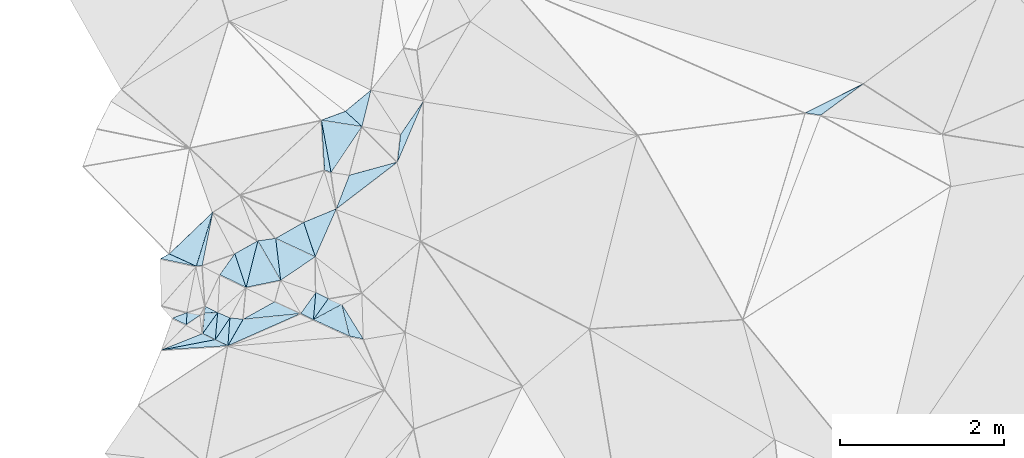
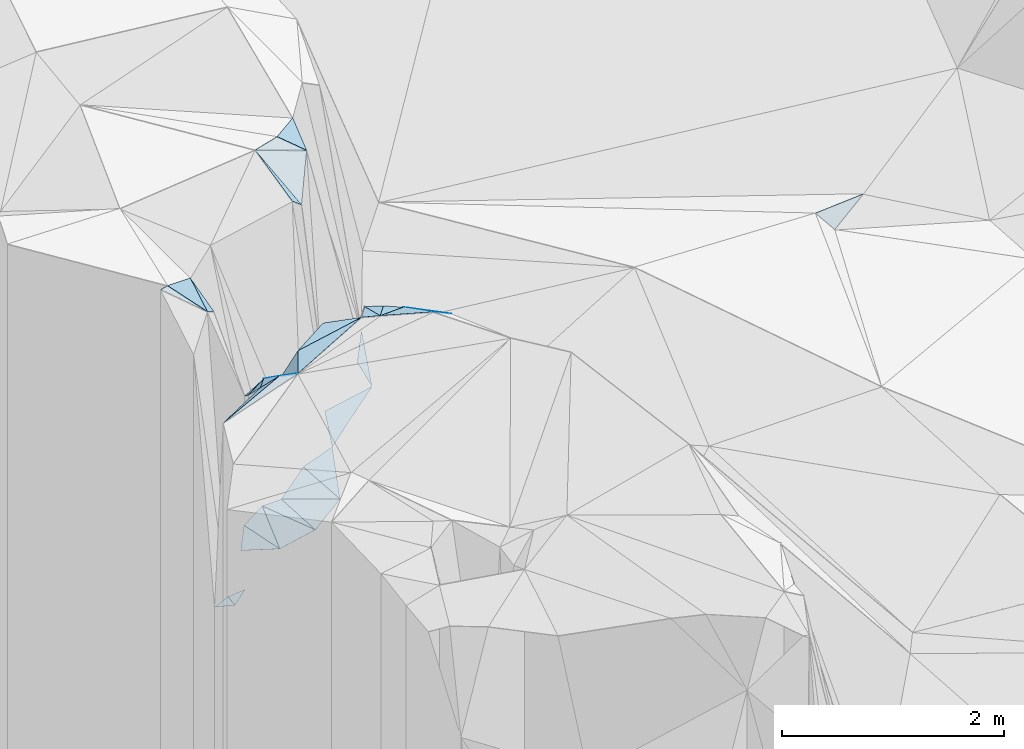
# One storey, part 174 of 275: 34 plates.
"""IFC2X3 building model written with IfcOpenShell, lengths in millimetres."""

import ifcopenshell
import ifcopenshell.guid

model = None  # the IFC model being written
_history = None  # IfcOwnerHistory: only IFC2X3 demands one
_inside = {}  # id of a spatial element -> (the spatial element, [elements in it])
_under = {}  # id of a project, library or spatial element -> (it, [spatial elements below it])
_declared = {}  # id of a project -> (the project, [libraries it declares])
_typed = {}  # id of a type object -> (the type object, [elements of that type])
_made_of = {}  # id of a material, layer set ... -> (it, [elements and type objects made of it])


def new_model(schema):
    """Start an empty IFC model of exactly this schema.

    Asked for "IFC4X3", IfcOpenShell would pick the latest addendum, in which some entities
    have other attributes; the version numbers below select the first issue.
    IFC2X3 requires an IfcOwnerHistory on every rooted entity: one is made here for all.
    """
    global model, _history
    if schema == "IFC4X3":
        model = ifcopenshell.file(schema_version=(4, 3, 0, 0))
    else:
        model = ifcopenshell.file(schema=schema)
    _inside.clear()
    _under.clear()
    _declared.clear()
    _typed.clear()
    _made_of.clear()
    _history = None
    if model.schema == "IFC2X3":
        org = make("IfcOrganization", Name="unknown")
        user = make(
            "IfcPersonAndOrganization",
            ThePerson=make("IfcPerson", FamilyName="unknown"),
            TheOrganization=org,
        )
        app = make(
            "IfcApplication",
            ApplicationDeveloper=org,
            Version="unknown",
            ApplicationFullName="unknown",
            ApplicationIdentifier="unknown",
        )
        _history = make(
            "IfcOwnerHistory",
            OwningUser=user,
            OwningApplication=app,
            ChangeAction="ADDED",
            CreationDate=0,
        )
    return model


def make(cls, **values):
    """One entity of the class cls with the attributes given. An attribute that is None is left unset."""
    return model.create_entity(
        cls, **{name: value for name, value in values.items() if value is not None}
    )


def rooted(cls, **values):
    """An entity with a GlobalId (a new one), such as an element, a storey or a relation."""
    return make(cls, GlobalId=ifcopenshell.guid.new(), OwnerHistory=_history, **values)


def si_unit(unit_type, name, prefix=None):
    """IfcSIUnit, for example si_unit("LENGTHUNIT", "METRE", prefix="MILLI")."""
    return make("IfcSIUnit", UnitType=unit_type, Prefix=prefix, Name=name)


def assignment(units):
    """IfcUnitAssignment: the units of a project."""
    return None if units is None else make("IfcUnitAssignment", Units=units)


def point(xyz):
    """IfcCartesianPoint."""
    return None if xyz is None else make("IfcCartesianPoint", Coordinates=xyz)


def direction(xyz):
    """IfcDirection."""
    return None if xyz is None else make("IfcDirection", DirectionRatios=xyz)


def frame(location, z_axis=None, x_axis=None):
    """IfcAxis2Placement3D, a coordinate frame: its origin and axes. An axis left out is left unset."""
    return make(
        "IfcAxis2Placement3D",
        Location=point(location),
        Axis=direction(z_axis),
        RefDirection=direction(x_axis),
    )


def origin_with_axes():
    """The frame at (0, 0, 0) with the z axis (0, 0, 1) and the x axis (1, 0, 0) written out."""
    return frame((0.0, 0.0, 0.0), z_axis=(0.0, 0.0, 1.0), x_axis=(1.0, 0.0, 0.0))


def place(relative_to, where):
    """IfcLocalPlacement: puts the frame where relative to a parent placement (None: the world)."""
    return make(
        "IfcLocalPlacement", PlacementRelTo=relative_to, RelativePlacement=where
    )


def context(
    kind, dimensions, precision=None, world=None, true_north=None, identifier=None
):
    """IfcGeometricRepresentationContext, for example the 3D "Model" context."""
    return make(
        "IfcGeometricRepresentationContext",
        ContextIdentifier=identifier,
        ContextType=kind,
        CoordinateSpaceDimension=dimensions,
        Precision=precision,
        WorldCoordinateSystem=world,
        TrueNorth=true_north,
    )


def subcontext(parent, identifier, kind, view, scale=None):
    """IfcGeometricRepresentationSubContext, for example "Body" below "Model"."""
    return make(
        "IfcGeometricRepresentationSubContext",
        ContextIdentifier=identifier,
        ContextType=kind,
        ParentContext=parent,
        TargetScale=scale,
        TargetView=view,
    )


def project(units=None, contexts=None):
    """IfcProject with its units and contexts."""
    return rooted(
        "IfcProject",
        Name="project",
        RepresentationContexts=contexts,
        UnitsInContext=assignment(units),
    )


def spatial(cls, under=None, at=None, **own):
    """A site, building, storey or space (cls), placed at a placement, below another one or the project."""
    s = rooted(cls, ObjectPlacement=at, **own)
    if under is not None:
        _under.setdefault(under.id(), (under, []))[1].append(s)
    return s


def polyline(points):
    """IfcPolyline through the points."""
    return make("IfcPolyline", Points=[point(p) for p in points])


def outline(outer, holes=None, kind="AREA"):
    """IfcArbitraryClosedProfileDef: a profile drawn as a closed curve; with holes, ...WithVoids."""
    if holes is None:
        return make("IfcArbitraryClosedProfileDef", ProfileType=kind, OuterCurve=outer)
    return make(
        "IfcArbitraryProfileDefWithVoids",
        ProfileType=kind,
        OuterCurve=outer,
        InnerCurves=holes,
    )


def extrude(swept, where, along, depth):
    """IfcExtrudedAreaSolid: the profile swept, set in the frame where, extruded along a direction by depth."""
    return make(
        "IfcExtrudedAreaSolid",
        SweptArea=swept,
        Position=where,
        ExtrudedDirection=direction(along),
        Depth=depth,
    )


def shape(context_of_items, identifier, shape_type, items):
    """IfcShapeRepresentation: the items that make up one representation, for example the "Body"."""
    return make(
        "IfcShapeRepresentation",
        ContextOfItems=context_of_items,
        RepresentationIdentifier=identifier,
        RepresentationType=shape_type,
        Items=items,
    )


def material(Name=None, Category=None):
    """IfcMaterial."""
    return make("IfcMaterial", Name=Name, Category=Category)


def made_of(thing, what):
    """Note that an element or type object is made of a material, layer set ...; save() writes the relation."""
    if what is not None:
        _made_of.setdefault(what.id(), (what, []))[1].append(thing)
    return thing


def type_object(cls, material=None, **own):
    """A type object (cls), such as IfcWallType, which elements share."""
    return made_of(rooted(cls, **own), material)


def element(
    cls,
    number,
    at=None,
    inside=None,
    cuts=None,
    type_object=None,
    material=None,
    context=None,
    identifier="Body",
    shape_type=None,
    held_by="IfcProductDefinitionShape",
    body=None,
    shapes=None,
    **own,
):
    """One element of the class cls, such as IfcWall. Its Tag is "e" and its number.

    at: its placement. inside: the storey or other place that contains it. cuts: it is an
    opening in that element (IfcRelVoidsElement). A single representation is given by context,
    identifier, shape_type and body (its items); several are given by shapes. held_by: the class
    of the entity that holds the representations. save() writes the other relations.
    """
    e = rooted(cls, Tag="e%d" % number, ObjectPlacement=at, **own)
    if body is not None:
        shapes = [shape(context, identifier, shape_type, body)]
    if shapes is not None:
        e.Representation = make(held_by, Representations=shapes)
    if inside is not None:
        _inside.setdefault(inside.id(), (inside, []))[1].append(e)
    if cuts is not None:
        rooted(
            "IfcRelVoidsElement", RelatingBuildingElement=cuts, RelatedOpeningElement=e
        )
    if type_object is not None:
        _typed.setdefault(type_object.id(), (type_object, []))[1].append(e)
    return made_of(e, material)


def aggregate(whole, parts):
    """IfcRelAggregates: a whole, such as a stair, and the parts it consists of."""
    return rooted("IfcRelAggregates", RelatingObject=whole, RelatedObjects=parts)


def save(model, path):
    """Write the relations noted so far, then the file.

    IfcRelAggregates (storeys below a building ...), IfcRelContainedInSpatialStructure (elements
    in a storey), IfcRelDefinesByType, IfcRelAssociatesMaterial and IfcRelDeclares: one each for
    every whole, place, type object, material and project.
    """
    for whole, parts in _under.values():
        aggregate(whole, parts)
    for where, things in _inside.values():
        rooted(
            "IfcRelContainedInSpatialStructure",
            RelatedElements=things,
            RelatingStructure=where,
        )
    for kind, things in _typed.values():
        rooted("IfcRelDefinesByType", RelatedObjects=things, RelatingType=kind)
    for what, things in _made_of.values():
        rooted("IfcRelAssociatesMaterial", RelatedObjects=things, RelatingMaterial=what)
    for by, libraries in _declared.values():
        rooted("IfcRelDeclares", RelatingContext=by, RelatedDefinitions=libraries)
    model.write(path)


model = new_model("IFC2X3")

# Units and contexts
model_context = context("Model", 3, precision=1e-05, world=origin_with_axes())
body_context = subcontext(model_context, "Body", "Model", "MODEL_VIEW")
ifc_project = project(units=[si_unit("LENGTHUNIT", "METRE", prefix="MILLI"), si_unit("AREAUNIT", "SQUARE_METRE"), si_unit("VOLUMEUNIT", "CUBIC_METRE"), si_unit("MASSUNIT", "GRAM", prefix="KILO"), si_unit("TIMEUNIT", "SECOND"), si_unit("PLANEANGLEUNIT", "RADIAN"), si_unit("SOLIDANGLEUNIT", "STERADIAN"), si_unit("THERMODYNAMICTEMPERATUREUNIT", "DEGREE_CELSIUS"), si_unit("LUMINOUSINTENSITYUNIT", "LUMEN")], contexts=[model_context])

# Site, building, storey
site_placement = place(None, origin_with_axes())
site = spatial("IfcSite", under=ifc_project, at=site_placement, CompositionType="ELEMENT")
building_placement = place(site_placement, origin_with_axes())
building = spatial("IfcBuilding", under=site, at=building_placement, Name="Undefined", CompositionType="ELEMENT")
storey_placement = place(building_placement, origin_with_axes())
storey = spatial("IfcBuildingStorey", under=building, at=storey_placement, Name="Undefined", CompositionType="ELEMENT", Elevation=0.0)

# Plates
ifc_material = material()
plate_type_1 = type_object("IfcPlateType", PredefinedType="NOTDEFINED")
plate_1_placement = place(storey_placement, frame((-136102.059956231, 93262.0576087373, 54479.5205283592), z_axis=(-0.119658069519682, 0.257357162709974, -0.958879156724504), x_axis=(0.353440063253771, 0.913586766906166, 0.201095353056975)))
element("IfcPlate", 1, at=plate_1_placement, inside=storey, type_object=plate_type_1, material=ifc_material, Name="00", context=body_context, shape_type="SweptSolid", body=[
    extrude(outline(polyline([(0.0, 0.0), (447.548889160156, 1.76078174263239e-09), (794.773498535156, 498.432586669922), (0.0, 0.0)])), frame((-8.85201319254618e-08, 2.18876761149539e-07, -0.5000001331573), z_axis=(0.0, 0.0, 1.0), x_axis=(1.0, 0.0, 0.0)), (0.0, 0.0, 1.0), 1.0),
])
plate_type_2 = type_object("IfcPlateType", PredefinedType="NOTDEFINED")
plate_2_placement = place(storey_placement, frame((-135041.539628917, 94572.7760186233, 54599.5185793243), z_axis=(-0.211432938409784, 0.168339358278525, -0.962786566695744), x_axis=(-0.392209356771163, -0.916879990058271, -0.0741815630186923)))
element("IfcPlate", 2, at=plate_2_placement, inside=storey, type_object=plate_type_2, material=ifc_material, Name="00", context=body_context, shape_type="SweptSolid", body=[
    extrude(outline(polyline([(0.0, 0.0), (808.826293945313, -1.57160684466362e-09), (483.911071777344, 99.6498031616211), (0.0, 0.0)])), frame((-8.85201319254618e-08, 2.18876761149539e-07, -0.5000001331573), z_axis=(0.0, 0.0, 1.0), x_axis=(1.0, 0.0, 0.0)), (0.0, 0.0, 1.0), 1.0),
])
plate_type_3 = type_object("IfcPlateType", PredefinedType="NOTDEFINED")
plate_3_placement = place(storey_placement, frame((-135774.293739208, 91679.1654943419, 56789.5865918103), z_axis=(-0.38020282266032, -0.414618868867303, -0.826762969187858), x_axis=(-0.924650624260084, 0.191278561828932, 0.329292779817736)))
element("IfcPlate", 3, at=plate_3_placement, inside=storey, type_object=plate_type_3, material=ifc_material, Name="00", context=body_context, shape_type="SweptSolid", body=[
    extrude(outline(polyline([(0.0, 0.0), (182.208679199219, -1.61526259034872e-09), (293.070587158203, 408.912750244141), (0.0, 0.0)])), frame((-8.85201319254618e-08, 2.18876761149539e-07, -0.5000001331573), z_axis=(0.0, 0.0, 1.0), x_axis=(1.0, 0.0, 0.0)), (0.0, 0.0, 1.0), 1.0),
])
plate_type_4 = type_object("IfcPlateType", PredefinedType="NOTDEFINED")
plate_4_placement = place(storey_placement, frame((-136283.879230588, 94340.7200018934, 57159.5710770173), z_axis=(-0.437740594458463, 0.269404179619282, -0.8577905105367), x_axis=(0.168438407355869, -0.912589430333872, -0.372570845035299)))
element("IfcPlate", 4, at=plate_4_placement, inside=storey, type_object=plate_type_4, material=ifc_material, Name="00", context=body_context, shape_type="SweptSolid", body=[
    extrude(outline(polyline([(0.0, 0.0), (697.853881835938, -1.03318598121405e-09), (637.955932617188, 78.1808013916016), (0.0, 0.0)])), frame((-8.85201319254618e-08, 2.18876761149539e-07, -0.5000001331573), z_axis=(0.0, 0.0, 1.0), x_axis=(1.0, 0.0, 0.0)), (0.0, 0.0, 1.0), 1.0),
])
plate_type_5 = type_object("IfcPlateType", PredefinedType="NOTDEFINED")
plate_5_placement = place(storey_placement, frame((-137056.178743322, 92872.9639135759, 54399.5049942715), z_axis=(-0.00587096308559347, 0.141336773812138, -0.989944164163224), x_axis=(0.497182111396843, -0.858518678310778, -0.125521420875052)))
element("IfcPlate", 5, at=plate_5_placement, inside=storey, type_object=plate_type_5, material=ifc_material, Name="00", context=body_context, shape_type="SweptSolid", body=[
    extrude(outline(polyline([(0.0, 0.0), (557.673767089844, 2.77941580861807e-09), (424.979675292969, 408.646881103516), (0.0, 0.0)])), frame((-8.85201319254618e-08, 2.18876761149539e-07, -0.5000001331573), z_axis=(0.0, 0.0, 1.0), x_axis=(1.0, 0.0, 0.0)), (0.0, 0.0, 1.0), 1.0),
])
plate_type_6 = type_object("IfcPlateType", PredefinedType="NOTDEFINED")
plate_6_placement = place(storey_placement, frame((-136778.962109518, 92394.1624225428, 54329.5044671322), z_axis=(-0.103421409674423, 0.0849979738680157, -0.990999170766196), x_axis=(-0.497182111452953, 0.858518678422199, 0.125521419890725)))
element("IfcPlate", 6, at=plate_6_placement, inside=storey, type_object=plate_type_6, material=ifc_material, Name="00", context=body_context, shape_type="SweptSolid", body=[
    extrude(outline(polyline([(0.0, 0.0), (557.673767089844, 2.77941580861807e-09), (473.395080566406, 202.477416992188), (0.0, 0.0)])), frame((-8.85201319254618e-08, 2.18876761149539e-07, -0.5000001331573), z_axis=(0.0, 0.0, 1.0), x_axis=(1.0, 0.0, 0.0)), (0.0, 0.0, 1.0), 1.0),
])
plate_type_7 = type_object("IfcPlateType", PredefinedType="NOTDEFINED")
plate_7_placement = place(storey_placement, frame((-137727.265224009, 91744.8296891179, 56619.6934589091), z_axis=(0.47813599606679, -0.62895166140146, -0.613029996725741), x_axis=(0.0599367299592715, 0.719723747835644, -0.691668500947675)))
element("IfcPlate", 7, at=plate_7_placement, inside=storey, type_object=plate_type_7, material=ifc_material, Name="00", context=body_context, shape_type="SweptSolid", body=[
    extrude(outline(polyline([(0.0, 0.0), (346.987030029297, 2.91038304567337e-11), (277.820190429688, 188.986633300781), (0.0, 0.0)])), frame((-8.85201319254618e-08, 2.18876761149539e-07, -0.5000001331573), z_axis=(0.0, 0.0, 1.0), x_axis=(1.0, 0.0, 0.0)), (0.0, 0.0, 1.0), 1.0),
])
plate_type_8 = type_object("IfcPlateType", PredefinedType="NOTDEFINED")
plate_8_placement = place(storey_placement, frame((-137235.677048889, 91918.8071439654, 56749.5034619952), z_axis=(0.115468442823451, -0.0227419632821938, -0.993050775045264), x_axis=(0.870682419546426, 0.483510126957181, 0.090166964142262)))
element("IfcPlate", 8, at=plate_8_placement, inside=storey, type_object=plate_type_8, material=ifc_material, Name="00", context=body_context, shape_type="SweptSolid", body=[
    extrude(outline(polyline([(0.0, 0.0), (443.621459960938, 5.15137799084187e-09), (651.907165527344, 280.565643310547), (0.0, 0.0)])), frame((-8.85201319254618e-08, 2.18876761149539e-07, -0.5000001331573), z_axis=(0.0, 0.0, 1.0), x_axis=(1.0, 0.0, 0.0)), (0.0, 0.0, 1.0), 1.0),
])
plate_type_9 = type_object("IfcPlateType", PredefinedType="NOTDEFINED")
plate_9_placement = place(storey_placement, frame((-137916.756443981, 92000.3592077676, 54229.5139100452), z_axis=(0.233638972256736, -0.0181857488493889, -0.972153336249793), x_axis=(0.960644936811236, -0.15017921580434, 0.233682495106778)))
element("IfcPlate", 9, at=plate_9_placement, inside=storey, type_object=plate_type_9, material=ifc_material, Name="00", context=body_context, shape_type="SweptSolid", body=[
    extrude(outline(polyline([(0.0, 0.0), (171.172424316406, -2.18278728425503e-09), (11.0999183654785, 147.230407714844), (0.0, 0.0)])), frame((-8.85201319254618e-08, 2.18876761149539e-07, -0.5000001331573), z_axis=(0.0, 0.0, 1.0), x_axis=(1.0, 0.0, 0.0)), (0.0, 0.0, 1.0), 1.0),
])
plate_type_10 = type_object("IfcPlateType", PredefinedType="NOTDEFINED")
plate_10_placement = place(storey_placement, frame((-136036.333452161, 92099.0304628926, 56699.5467298105), z_axis=(-0.15791157055637, -0.391595763291411, -0.906485903948119), x_axis=(0.221093133110351, -0.908718678826235, 0.354045462114331)))
element("IfcPlate", 10, at=plate_10_placement, inside=storey, type_object=plate_type_10, material=ifc_material, Name="00", context=body_context, shape_type="SweptSolid", body=[
    extrude(outline(polyline([(0.0, 0.0), (423.674407958984, -3.39059624820948e-09), (141.618179321289, 390.569183349609), (0.0, 0.0)])), frame((-8.85201319254618e-08, 2.18876761149539e-07, -0.5000001331573), z_axis=(0.0, 0.0, 1.0), x_axis=(1.0, 0.0, 0.0)), (0.0, 0.0, 1.0), 1.0),
])
plate_type_11 = type_object("IfcPlateType", PredefinedType="NOTDEFINED")
plate_11_placement = place(storey_placement, frame((-136533.931140818, 91988.4646315607, 56829.5063266509), z_axis=(0.122594291322905, -0.10109611628365, -0.987294391256933), x_axis=(-0.912234884951929, -0.403294824262796, -0.0719777701765088)))
element("IfcPlate", 11, at=plate_11_placement, inside=storey, type_object=plate_type_11, material=ifc_material, Name="00", context=body_context, shape_type="SweptSolid", body=[
    extrude(outline(polyline([(0.0, 0.0), (972.522521972656, -7.45058059692383e-09), (674.020385742188, 222.253234863281), (0.0, 0.0)])), frame((-8.85201319254618e-08, 2.18876761149539e-07, -0.5000001331573), z_axis=(0.0, 0.0, 1.0), x_axis=(1.0, 0.0, 0.0)), (0.0, 0.0, 1.0), 1.0),
])
plate_type_12 = type_object("IfcPlateType", PredefinedType="NOTDEFINED")
plate_12_placement = place(storey_placement, frame((-136380.864860161, 91913.9399705625, 56839.5263415291), z_axis=(-0.0878450910355811, -0.308088475756241, -0.947293371182944), x_axis=(-0.897906971206371, 0.436264420904473, -0.0586210381338215)))
element("IfcPlate", 12, at=plate_12_placement, inside=storey, type_object=plate_type_12, material=ifc_material, Name="00", context=body_context, shape_type="SweptSolid", body=[
    extrude(outline(polyline([(0.0, 0.0), (170.587219238281, -8.65838956087828e-10), (124.27660369873, 326.121643066406), (0.0, 0.0)])), frame((-8.85201319254618e-08, 2.18876761149539e-07, -0.5000001331573), z_axis=(0.0, 0.0, 1.0), x_axis=(1.0, 0.0, 0.0)), (0.0, 0.0, 1.0), 1.0),
])
plate_13_placement = place(storey_placement, frame((-137421.244802107, 91596.0211696216, 56759.5947142821), z_axis=(-0.166923250574729, -0.561383550677409, -0.810546196984719), x_axis=(-0.893314066350711, 0.434032874993562, -0.116642369166531)))
element("IfcPlate", 13, at=plate_13_placement, inside=storey, type_object=plate_type_12, material=ifc_material, Name="00", context=body_context, shape_type="SweptSolid", body=[
    extrude(outline(polyline([(0.0, 0.0), (171.464279174805, 1.81898940354586e-09), (152.801498413086, 387.106842041016), (0.0, 0.0)])), frame((-8.85201319254618e-08, 2.18876761149539e-07, -0.5000001331573), z_axis=(0.0, 0.0, 1.0), x_axis=(1.0, 0.0, 0.0)), (0.0, 0.0, 1.0), 1.0),
])
plate_14_placement = place(storey_placement, frame((-136283.754832411, 94340.7566621266, 57159.5398509111), z_axis=(-0.188930266344674, 0.342723713116447, -0.920242256651261), x_axis=(0.936802642153927, 0.343908189274336, -0.064249256832038)))
element("IfcPlate", 14, at=plate_14_placement, inside=storey, type_object=plate_type_12, material=ifc_material, Name="00", context=body_context, shape_type="SweptSolid", body=[
    extrude(outline(polyline([(0.0, 0.0), (311.287658691406, -1.77533365786076e-09), (443.962371826172, 262.863891601563), (0.0, 0.0)])), frame((-8.85201319254618e-08, 2.18876761149539e-07, -0.5000001331573), z_axis=(0.0, 0.0, 1.0), x_axis=(1.0, 0.0, 0.0)), (0.0, 0.0, 1.0), 1.0),
])
plate_type_13 = type_object("IfcPlateType", PredefinedType="NOTDEFINED")
plate_15_placement = place(storey_placement, frame((-136351.816616279, 92243.8744430122, 56729.528865528), z_axis=(-0.146366744917574, -0.301247854111902, -0.942245459726503), x_axis=(0.8994537542401, -0.437015953923184, 1.27365890829146e-10)))
element("IfcPlate", 15, at=plate_15_placement, inside=storey, type_object=plate_type_13, material=ifc_material, Name="00", context=body_context, shape_type="SweptSolid", body=[
    extrude(outline(polyline([(0.0, 0.0), (170.293869018555, -7.38509697839618e-10), (118.031265258789, 328.43359375), (0.0, 0.0)])), frame((-8.85201319254618e-08, 2.18876761149539e-07, -0.5000001331573), z_axis=(0.0, 0.0, 1.0), x_axis=(1.0, 0.0, 0.0)), (0.0, 0.0, 1.0), 1.0),
])
plate_type_14 = type_object("IfcPlateType", PredefinedType="NOTDEFINED")
plate_16_placement = place(storey_placement, frame((-137199.394911504, 92306.6960184945, 54319.509138915), z_axis=(0.0826585991131099, 0.171568534550966, -0.981698423114091), x_axis=(-0.900895888021061, 0.434035250811203, -1.27781555553758e-10)))
element("IfcPlate", 16, at=plate_16_placement, inside=storey, type_object=plate_type_14, material=ifc_material, Name="00", context=body_context, shape_type="SweptSolid", body=[
    extrude(outline(polyline([(0.0, 0.0), (354.682952880859, -3.10683390125632e-09), (301.395935058594, 315.056335449219), (0.0, 0.0)])), frame((-8.85201319254618e-08, 2.18876761149539e-07, -0.5000001331573), z_axis=(0.0, 0.0, 1.0), x_axis=(1.0, 0.0, 0.0)), (0.0, 0.0, 1.0), 1.0),
])
plate_type_15 = type_object("IfcPlateType", PredefinedType="NOTDEFINED")
plate_17_placement = place(storey_placement, frame((-137199.44067284, 92306.6812712325, 54319.5050798734), z_axis=(-0.00885750267798895, 0.142074266558931, -0.989816370559737), x_axis=(-0.314867008217703, 0.939106684986971, 0.137613231009287)))
element("IfcPlate", 17, at=plate_17_placement, inside=storey, type_object=plate_type_15, material=ifc_material, Name="00", context=body_context, shape_type="SweptSolid", body=[
    extrude(outline(polyline([(0.0, 0.0), (436.004577636719, -1.12049747258425e-09), (497.701171875, 316.059387207031), (0.0, 0.0)])), frame((-8.85201319254618e-08, 2.18876761149539e-07, -0.5000001331573), z_axis=(0.0, 0.0, 1.0), x_axis=(1.0, 0.0, 0.0)), (0.0, 0.0, 1.0), 1.0),
])
plate_type_16 = type_object("IfcPlateType", PredefinedType="NOTDEFINED")
plate_18_placement = place(storey_placement, frame((-137805.425162974, 92563.7117018913, 56989.6276993288), z_axis=(-0.661536313047104, 0.0892998763228588, -0.744577221387255), x_axis=(-0.69046445989397, 0.31490237770909, 0.651226014634313)))
element("IfcPlate", 18, at=plate_18_placement, inside=storey, type_object=plate_type_16, material=ifc_material, Name="00", context=body_context, shape_type="SweptSolid", body=[
    extrude(outline(polyline([(0.0, 0.0), (476.025207519531, -8.51287040859461e-10), (2.94102072715759, 694.903869628906), (0.0, 0.0)])), frame((-8.85201319254618e-08, 2.18876761149539e-07, -0.5000001331573), z_axis=(0.0, 0.0, 1.0), x_axis=(1.0, 0.0, 0.0)), (0.0, 0.0, 1.0), 1.0),
])
plate_type_17 = type_object("IfcPlateType", PredefinedType="NOTDEFINED")
plate_19_placement = place(storey_placement, frame((-137544.99952724, 92000.3800540581, 56499.6690618481), z_axis=(0.511527122909677, -0.547989184874954, -0.661851838244657), x_axis=(-0.802259895969385, -0.0286967511151625, -0.596284794200411)))
element("IfcPlate", 19, at=plate_19_placement, inside=storey, type_object=plate_type_17, material=ifc_material, Name="00", context=body_context, shape_type="SweptSolid", body=[
    extrude(outline(polyline([(0.0, 0.0), (201.246124267578, -8.11269273981452e-10), (228.07893371582, 96.8504028320313), (0.0, 0.0)])), frame((-8.85201319254618e-08, 2.18876761149539e-07, -0.5000001331573), z_axis=(0.0, 0.0, 1.0), x_axis=(1.0, 0.0, 0.0)), (0.0, 0.0, 1.0), 1.0),
])
plate_type_18 = type_object("IfcPlateType", PredefinedType="NOTDEFINED")
plate_20_placement = place(storey_placement, frame((-137545.099588505, 92000.3656510625, 56499.6223863009), z_axis=(0.311405086233215, -0.576797865730333, -0.755202684288805), x_axis=(-0.0710901019730782, -0.806631580154712, 0.586763744021875)))
element("IfcPlate", 20, at=plate_20_placement, inside=storey, type_object=plate_type_18, material=ifc_material, Name="00", context=body_context, shape_type="SweptSolid", body=[
    extrude(outline(polyline([(0.0, 0.0), (409.023223876953, -6.69388100504875e-10), (289.470123291016, 170.607894897461), (0.0, 0.0)])), frame((-8.85201319254618e-08, 2.18876761149539e-07, -0.5000001331573), z_axis=(0.0, 0.0, 1.0), x_axis=(1.0, 0.0, 0.0)), (0.0, 0.0, 1.0), 1.0),
])
plate_type_19 = type_object("IfcPlateType", PredefinedType="NOTDEFINED")
plate_21_placement = place(storey_placement, frame((-137395.765075473, 91935.1624311923, 56519.7318141792), z_axis=(0.724394078296631, -0.433110573327725, -0.536347322730807), x_axis=(0.571012384751079, -0.0589568319400741, 0.818821682925212)))
element("IfcPlate", 21, at=plate_21_placement, inside=storey, type_object=plate_type_19, material=ifc_material, Name="00", context=body_context, shape_type="SweptSolid", body=[
    extrude(outline(polyline([(0.0, 0.0), (280.891448974609, 1.01863406598568e-10), (202.213348388672, 363.744079589844), (0.0, 0.0)])), frame((-8.85201319254618e-08, 2.18876761149539e-07, -0.5000001331573), z_axis=(0.0, 0.0, 1.0), x_axis=(1.0, 0.0, 0.0)), (0.0, 0.0, 1.0), 1.0),
])
plate_type_20 = type_object("IfcPlateType", PredefinedType="NOTDEFINED")
plate_22_placement = place(storey_placement, frame((-137928.30217167, 91853.1630664529, 54229.5008296266), z_axis=(0.0578562641190579, -0.00450335635736365, -0.998314766235432), x_axis=(-0.9008951211217, 0.430645363862968, -0.0541530361332549)))
element("IfcPlate", 22, at=plate_22_placement, inside=storey, type_object=plate_type_20, material=ifc_material, Name="00", context=body_context, shape_type="SweptSolid", body=[
    extrude(outline(polyline([(0.0, 0.0), (184.661849975586, -2.58660293184221e-09), (53.0699768066406, 137.780899047852), (0.0, 0.0)])), frame((-8.85201319254618e-08, 2.18876761149539e-07, -0.5000001331573), z_axis=(0.0, 0.0, 1.0), x_axis=(1.0, 0.0, 0.0)), (0.0, 0.0, 1.0), 1.0),
])
plate_type_21 = type_object("IfcPlateType", PredefinedType="NOTDEFINED")
plate_23_placement = place(storey_placement, frame((-138229.354587529, 91545.2214568257, 56529.5336861825), z_axis=(0.248799966207836, 0.261444914905045, -0.932601272401702), x_axis=(0.936783840158062, 0.179639713204846, 0.300275890238287)))
element("IfcPlate", 23, at=plate_23_placement, inside=storey, type_object=plate_type_21, material=ifc_material, Name="00", context=body_context, shape_type="SweptSolid", body=[
    extrude(outline(polyline([(0.0, 0.0), (699.356872558594, -2.03726813197136e-09), (835.48193359375, 104.259124755859), (0.0, 0.0)])), frame((-8.85201319254618e-08, 2.18876761149539e-07, -0.5000001331573), z_axis=(0.0, 0.0, 1.0), x_axis=(1.0, 0.0, 0.0)), (0.0, 0.0, 1.0), 1.0),
])
plate_type_22 = type_object("IfcPlateType", PredefinedType="NOTDEFINED")
plate_24_placement = place(storey_placement, frame((-138229.304308874, 91544.8264723075, 56529.6131358534), z_axis=(0.349352739448721, -0.528524234459154, -0.773702007900354), x_axis=(0.916323583563899, 0.365185004018961, 0.16428938810613)))
element("IfcPlate", 24, at=plate_24_placement, inside=storey, type_object=plate_type_22, material=ifc_material, Name="00", context=body_context, shape_type="SweptSolid", body=[
    extrude(outline(polyline([(0.0, 0.0), (547.813842773438, 6.2354956753552e-09), (680.705688476563, 160.436141967773), (0.0, 0.0)])), frame((-8.85201319254618e-08, 2.18876761149539e-07, -0.5000001331573), z_axis=(0.0, 0.0, 1.0), x_axis=(1.0, 0.0, 0.0)), (0.0, 0.0, 1.0), 1.0),
])
plate_type_23 = type_object("IfcPlateType", PredefinedType="NOTDEFINED")
plate_25_placement = place(storey_placement, frame((-136198.705331409, 92169.4967773296, 56729.5301421082), z_axis=(-0.266615459243882, -0.2143649945798, -0.939661559281306), x_axis=(0.904560210935953, -0.392199584716455, -0.167183463715003)))
element("IfcPlate", 25, at=plate_25_placement, inside=storey, type_object=plate_type_23, material=ifc_material, Name="00", context=body_context, shape_type="SweptSolid", body=[
    extrude(outline(polyline([(0.0, 0.0), (179.443588256836, 4.51109372079372e-10), (-83.0344543457031, 322.033050537109), (0.0, 0.0)])), frame((-8.85201319254618e-08, 2.18876761149539e-07, -0.5000001331573), z_axis=(0.0, 0.0, 1.0), x_axis=(1.0, 0.0, 0.0)), (0.0, 0.0, 1.0), 1.0),
])
plate_type_24 = type_object("IfcPlateType", PredefinedType="NOTDEFINED")
plate_26_placement = place(storey_placement, frame((-136357.940533006, 92678.7909274587, 54349.5388130399), z_axis=(0.114422433729327, 0.369127696800213, -0.92230811018576), x_axis=(-0.905131939300641, 0.421379222422443, 0.0563535568399885)))
element("IfcPlate", 26, at=plate_26_placement, inside=storey, type_object=plate_type_24, material=ifc_material, Name="00", context=body_context, shape_type="SweptSolid", body=[
    extrude(outline(polyline([(0.0, 0.0), (532.353271484375, -1.86264514923096e-09), (312.762237548828, 346.236602783203), (0.0, 0.0)])), frame((-8.85201319254618e-08, 2.18876761149539e-07, -0.5000001331573), z_axis=(0.0, 0.0, 1.0), x_axis=(1.0, 0.0, 0.0)), (0.0, 0.0, 1.0), 1.0),
])
plate_type_25 = type_object("IfcPlateType", PredefinedType="NOTDEFINED")
plate_27_placement = place(storey_placement, frame((-136778.919055656, 92394.1677866609, 54329.5023448756), z_axis=(-0.0174036197655489, 0.0957182002948204, -0.99525631882012), x_axis=(-0.118352724216763, 0.988211631752845, 0.0971102648480082)))
element("IfcPlate", 27, at=plate_27_placement, inside=storey, type_object=plate_type_25, material=ifc_material, Name="00", context=body_context, shape_type="SweptSolid", body=[
    extrude(outline(polyline([(0.0, 0.0), (514.878601074219, -1.29512045532465e-09), (233.258850097656, 451.763549804688), (0.0, 0.0)])), frame((-8.85201319254618e-08, 2.18876761149539e-07, -0.5000001331573), z_axis=(0.0, 0.0, 1.0), x_axis=(1.0, 0.0, 0.0)), (0.0, 0.0, 1.0), 1.0),
])
plate_type_26 = type_object("IfcPlateType", PredefinedType="NOTDEFINED")
plate_28_placement = place(storey_placement, frame((-135790.44730423, 94263.6361545754, 57029.5395652685), z_axis=(-0.189351759158074, 0.34097579081285, -0.920804768332188), x_axis=(-0.547291264398563, -0.815243285280603, -0.189342699140767)))
element("IfcPlate", 28, at=plate_28_placement, inside=storey, type_object=plate_type_26, material=ifc_material, Name="00", context=body_context, shape_type="SweptSolid", body=[
    extrude(outline(polyline([(0.0, 0.0), (686.585754394531, 8.81846062839031e-09), (182.49723815918, 482.591705322266), (0.0, 0.0)])), frame((-8.85201319254618e-08, 2.18876761149539e-07, -0.5000001331573), z_axis=(0.0, 0.0, 1.0), x_axis=(1.0, 0.0, 0.0)), (0.0, 0.0, 1.0), 1.0),
])
plate_type_27 = type_object("IfcPlateType", PredefinedType="NOTDEFINED")
plate_29_placement = place(storey_placement, frame((-137545.32687534, 92000.3671172529, 56499.5968166151), z_axis=(-0.14307562127185, -0.573922966815918, -0.80631370741101), x_axis=(0.909249579827262, -0.397989086653699, 0.12194215222187)))
element("IfcPlate", 29, at=plate_29_placement, inside=storey, type_object=plate_type_27, material=ifc_material, Name="00", context=body_context, shape_type="SweptSolid", body=[
    extrude(outline(polyline([(0.0, 0.0), (164.012191772461, 1.7134880181402e-09), (134.136367797852, 386.403198242188), (0.0, 0.0)])), frame((-8.85201319254618e-08, 2.18876761149539e-07, -0.5000001331573), z_axis=(0.0, 0.0, 1.0), x_axis=(1.0, 0.0, 0.0)), (0.0, 0.0, 1.0), 1.0),
])
plate_type_28 = type_object("IfcPlateType", PredefinedType="NOTDEFINED")
plate_30_placement = place(storey_placement, frame((-136102.08250819, 93262.0704012799, 54479.5275385078), z_axis=(-0.164855054643648, 0.282923157275719, -0.944868931670197), x_axis=(-0.393749306592644, -0.897207004738825, -0.19995267991552)))
element("IfcPlate", 30, at=plate_30_placement, inside=storey, type_object=plate_type_28, material=ifc_material, Name="00", context=body_context, shape_type="SweptSolid", body=[
    extrude(outline(polyline([(0.0, 0.0), (650.15380859375, -1.83354131877422e-09), (300.236633300781, 308.638885498047), (0.0, 0.0)])), frame((-8.85201319254618e-08, 2.18876761149539e-07, -0.5000001331573), z_axis=(0.0, 0.0, 1.0), x_axis=(1.0, 0.0, 0.0)), (0.0, 0.0, 1.0), 1.0),
])
plate_type_29 = type_object("IfcPlateType", PredefinedType="NOTDEFINED")
plate_31_placement = place(storey_placement, frame((-137805.330992208, 92563.9092969696, 56989.6320412913), z_axis=(-0.473106962969267, 0.484433715958157, -0.735862607035423), x_axis=(-0.776684001924262, 0.164914353815386, 0.607918758602304)))
element("IfcPlate", 31, at=plate_31_placement, inside=storey, type_object=plate_type_29, material=ifc_material, Name="00", context=body_context, shape_type="SweptSolid", body=[
    extrude(outline(polyline([(0.0, 0.0), (559.285278320313, -4.26371116191149e-09), (468.455047607422, 84.5569152832031), (0.0, 0.0)])), frame((-8.85201319254618e-08, 2.18876761149539e-07, -0.5000001331573), z_axis=(0.0, 0.0, 1.0), x_axis=(1.0, 0.0, 0.0)), (0.0, 0.0, 1.0), 1.0),
])
plate_type_30 = type_object("IfcPlateType", PredefinedType="NOTDEFINED")
plate_32_placement = place(storey_placement, frame((-129690.395523725, 94784.8894842385, 54099.7472249892), z_axis=(-0.524290001701147, 0.685268873770836, -0.505496354840527), x_axis=(-0.804726902040123, -0.592836529268969, 0.030975194869916)))
element("IfcPlate", 32, at=plate_32_placement, inside=storey, type_object=plate_type_30, material=ifc_material, Name="00", context=body_context, shape_type="SweptSolid", body=[
    extrude(outline(polyline([(0.0, 0.0), (645.677917480469, -5.5297277867794e-10), (787.234558105469, 261.651916503906), (0.0, 0.0)])), frame((-8.85201319254618e-08, 2.18876761149539e-07, -0.5000001331573), z_axis=(0.0, 0.0, 1.0), x_axis=(1.0, 0.0, 0.0)), (0.0, 0.0, 1.0), 1.0),
])
plate_type_31 = type_object("IfcPlateType", PredefinedType="NOTDEFINED")
plate_33_placement = place(storey_placement, frame((-137603.970472546, 93221.2054982497, 56889.5378770451), z_axis=(-0.381184537036874, -0.0238478166297403, -0.924191338612291), x_axis=(-0.194585229837117, -0.975204059162651, 0.105421209070687)))
element("IfcPlate", 33, at=plate_33_placement, inside=storey, type_object=plate_type_31, material=ifc_material, Name="00", context=body_context, shape_type="SweptSolid", body=[
    extrude(outline(polyline([(0.0, 0.0), (664.002990722656, -2.12457962334156e-09), (690.960693359375, 73.9816360473633), (0.0, 0.0)])), frame((-8.85201319254618e-08, 2.18876761149539e-07, -0.5000001331573), z_axis=(0.0, 0.0, 1.0), x_axis=(1.0, 0.0, 0.0)), (0.0, 0.0, 1.0), 1.0),
])
plate_type_32 = type_object("IfcPlateType", PredefinedType="NOTDEFINED")
plate_34_placement = place(storey_placement, frame((-135790.518967702, 94263.5594514892, 57029.5378873098), z_axis=(-0.3327648523173, 0.187553733018567, -0.924170520138489), x_axis=(-0.684984275431568, 0.625487678054269, 0.373579585916801)))
element("IfcPlate", 34, at=plate_34_placement, inside=storey, type_object=plate_type_32, material=ifc_material, Name="00", context=body_context, shape_type="SweptSolid", body=[
    extrude(outline(polyline([(0.0, 0.0), (294.448638916016, 5.05679054185748e-10), (219.732727050781, 402.762390136719), (0.0, 0.0)])), frame((-8.85201319254618e-08, 2.18876761149539e-07, -0.5000001331573), z_axis=(0.0, 0.0, 1.0), x_axis=(1.0, 0.0, 0.0)), (0.0, 0.0, 1.0), 1.0),
])

save(model, "model.ifc")
